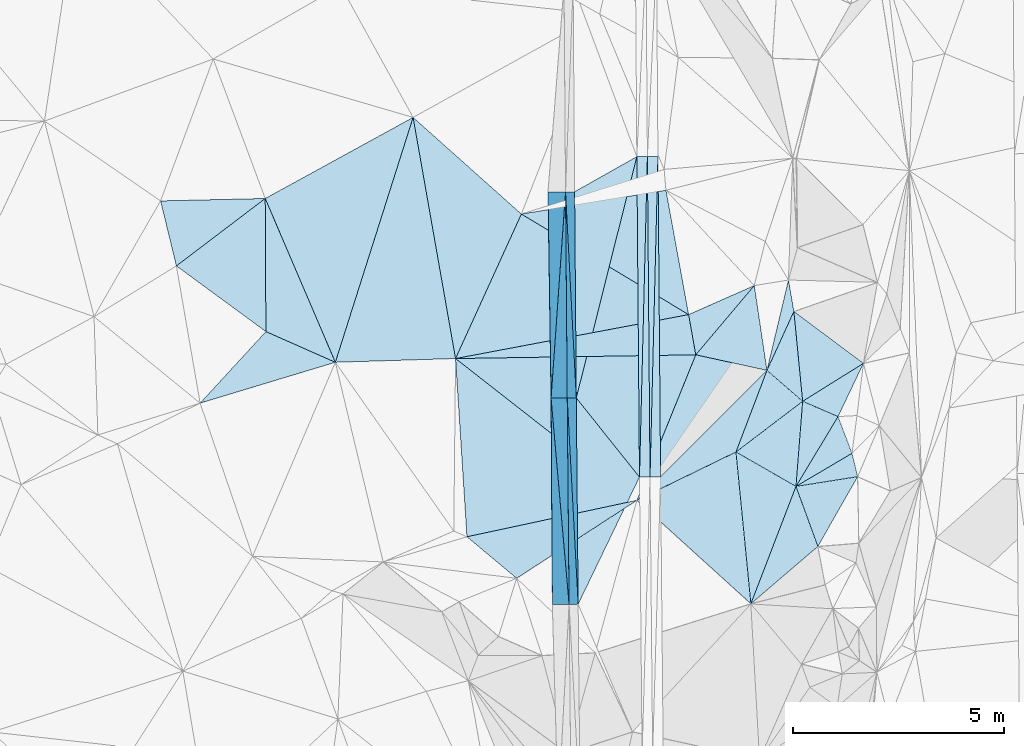
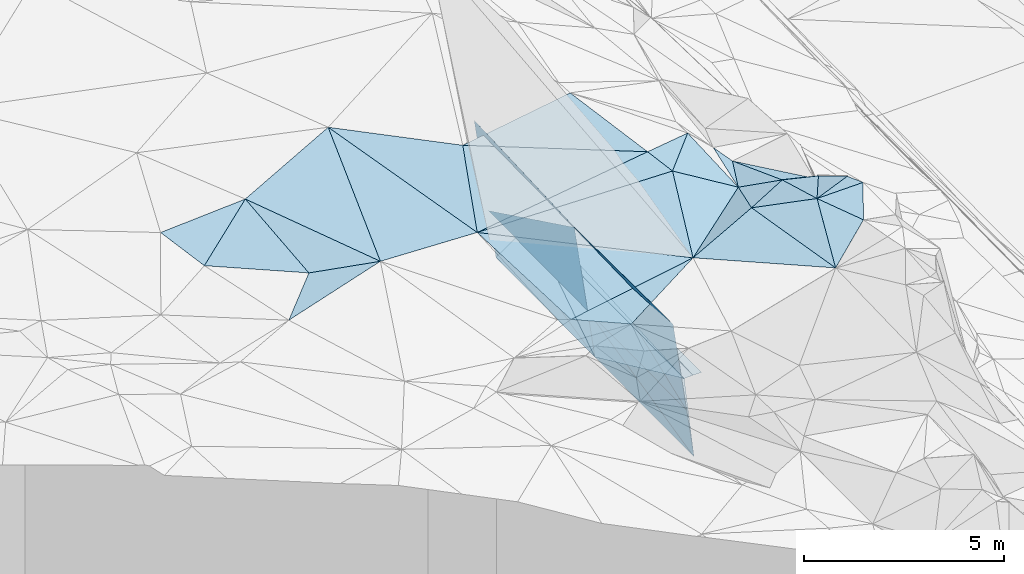
# One storey, part 19 of 275: 45 plates.
"""IFC2X3 building model written with IfcOpenShell, lengths in millimetres."""

from ifc_helpers import new_model, si_unit, frame, origin_with_axes, place, context, subcontext, project, spatial, polyline, outline, extrude, material, type_object, element, save


model = new_model("IFC2X3")

# Units and contexts
model_context = context("Model", 3, precision=1e-05, world=origin_with_axes())
body_context = subcontext(model_context, "Body", "Model", "MODEL_VIEW")
ifc_project = project(units=[si_unit("LENGTHUNIT", "METRE", prefix="MILLI"), si_unit("AREAUNIT", "SQUARE_METRE"), si_unit("VOLUMEUNIT", "CUBIC_METRE"), si_unit("MASSUNIT", "GRAM", prefix="KILO"), si_unit("TIMEUNIT", "SECOND"), si_unit("PLANEANGLEUNIT", "RADIAN"), si_unit("SOLIDANGLEUNIT", "STERADIAN"), si_unit("THERMODYNAMICTEMPERATUREUNIT", "DEGREE_CELSIUS"), si_unit("LUMINOUSINTENSITYUNIT", "LUMEN")], contexts=[model_context])

# Site, building, storey
site_placement = place(None, origin_with_axes())
site = spatial("IfcSite", under=ifc_project, at=site_placement, CompositionType="ELEMENT")
building_placement = place(site_placement, origin_with_axes())
building = spatial("IfcBuilding", under=site, at=building_placement, Name="Undefined", CompositionType="ELEMENT")
storey_placement = place(building_placement, origin_with_axes())
storey = spatial("IfcBuildingStorey", under=building, at=storey_placement, Name="Undefined", CompositionType="ELEMENT", Elevation=0.0)

# Plates
ifc_material = material()
plate_type_1 = type_object("IfcPlateType", PredefinedType="NOTDEFINED")
plate_1_placement = place(storey_placement, frame((-103921.728239516, 36919.7702889844, 41973.6237308018), z_axis=(0.0497692492091022, 0.0208905497116194, -0.998542240852088), x_axis=(0.998723320468431, 0.00761374111496485, 0.0499375620024224)))
element("IfcPlate", 1, at=plate_1_placement, inside=storey, type_object=plate_type_1, material=ifc_material, Name="00_PR", context=body_context, shape_type="SweptSolid", body=[
    extrude(outline(polyline([(0.0, 0.0), (250.312576293945, -3.78349795937538e-10), (-3.00748419761658, 7591.955078125), (0.0, 0.0)])), frame((-8.85201319254618e-08, 2.18876761149539e-07, -0.5000001331573), z_axis=(0.0, 0.0, 1.0), x_axis=(1.0, 0.0, 0.0)), (0.0, 0.0, 1.0), 1.0),
])
plate_2_placement = place(storey_placement, frame((-103671.735246054, 36921.6761023971, 41986.1237297089), z_axis=(0.049743498958775, 0.0208912133031926, -0.998543510077582), x_axis=(0.00825023810131896, -0.999755697538456, -0.020505579988562)))
element("IfcPlate", 2, at=plate_2_placement, inside=storey, type_object=plate_type_1, material=ifc_material, Name="00_PR", context=body_context, shape_type="SweptSolid", body=[
    extrude(outline(polyline([(0.0, 0.0), (7591.640625, 2.20461515709758e-08), (7592.0546875, 250.312301635742), (0.0, 0.0)])), frame((-8.85201319254618e-08, 2.18876761149539e-07, -0.5000001331573), z_axis=(0.0, 0.0, 1.0), x_axis=(1.0, 0.0, 0.0)), (0.0, 0.0, 1.0), 1.0),
])
plate_3_placement = place(storey_placement, frame((-103609.137362637, 29331.8896114708, 41830.4522061954), z_axis=(-0.0201732460180045, 0.0203365516157149, -0.999589648212444), x_axis=(0.0246672648762927, 0.999498886520807, 0.0198368819926245)))
element("IfcPlate", 3, at=plate_3_placement, inside=storey, type_object=plate_type_1, material=ifc_material, Name="00_PR", context=body_context, shape_type="SweptSolid", body=[
    extrude(outline(polyline([(0.0, 0.0), (7595.498046875, 6.41739461570978e-09), (8.28653717041016, 249.912078857422), (0.0, 0.0)])), frame((-8.85201319254618e-08, 2.18876761149539e-07, -0.5000001331573), z_axis=(0.0, 0.0, 1.0), x_axis=(1.0, 0.0, 0.0)), (0.0, 0.0, 1.0), 1.0),
])
plate_4_placement = place(storey_placement, frame((-103421.777179473, 36923.5816405609, 41981.1232056417), z_axis=(-0.0201473935407606, 0.0203359241728158, -0.999590182385537), x_axis=(-0.0246672648625445, -0.999498886521437, -0.0198368819780045)))
element("IfcPlate", 4, at=plate_4_placement, inside=storey, type_object=plate_type_1, material=ifc_material, Name="00_PR", context=body_context, shape_type="SweptSolid", body=[
    extrude(outline(polyline([(0.0, 0.0), (7595.498046875, 6.41739461570978e-09), (7.97231960296631, 249.923141479492), (0.0, 0.0)])), frame((-8.85201319254618e-08, 2.18876761149539e-07, -0.5000001331573), z_axis=(0.0, 0.0, 1.0), x_axis=(1.0, 0.0, 0.0)), (0.0, 0.0, 1.0), 1.0),
])
plate_type_2 = type_object("IfcPlateType", PredefinedType="NOTDEFINED")
plate_5_placement = place(storey_placement, frame((-101573.44969805, 29924.7296562743, 45869.5076663774), z_axis=(0.168990342988045, -0.0436568442276108, -0.98465036633765), x_axis=(0.85501951198308, -0.490462355806167, 0.168488313141538)))
element("IfcPlate", 5, at=plate_5_placement, inside=storey, type_object=plate_type_2, material=ifc_material, Name="00", context=body_context, shape_type="SweptSolid", body=[
    extrude(outline(polyline([(0.0, 0.0), (1661.83630371094, 1.65528035722673e-09), (2101.95190429688, 2944.82568359375), (0.0, 0.0)])), frame((-8.85201319254618e-08, 2.18876761149539e-07, -0.5000001331573), z_axis=(0.0, 0.0, 1.0), x_axis=(1.0, 0.0, 0.0)), (0.0, 0.0, 1.0), 1.0),
])
plate_type_3 = type_object("IfcPlateType", PredefinedType="NOTDEFINED")
plate_6_placement = place(storey_placement, frame((-103921.327531141, 28780.4761888303, 45858.565501627), z_axis=(0.220043812322641, -0.443233428239793, -0.868979199261593), x_axis=(0.696354859847022, 0.695205713028764, -0.178266445916226)))
element("IfcPlate", 6, at=plate_6_placement, inside=storey, type_object=plate_type_3, material=ifc_material, Name="00", context=body_context, shape_type="SweptSolid", body=[
    extrude(outline(polyline([(0.0, 0.0), (4425.958984375, -1.13213900476694e-08), (2428.36572265625, 961.597778320313), (0.0, 0.0)])), frame((-8.85201319254618e-08, 2.18876761149539e-07, -0.5000001331573), z_axis=(0.0, 0.0, 1.0), x_axis=(1.0, 0.0, 0.0)), (0.0, 0.0, 1.0), 1.0),
])
plate_type_4 = type_object("IfcPlateType", PredefinedType="NOTDEFINED")
plate_7_placement = place(storey_placement, frame((-100152.673837097, 29109.5207801058, 46149.5290304799), z_axis=(-0.0842694409372019, -0.325084643046942, -0.941922839822442), x_axis=(0.0738510628752179, 0.940647822764666, -0.331251707980947)))
element("IfcPlate", 7, at=plate_7_placement, inside=storey, type_object=plate_type_4, material=ifc_material, Name="00", context=body_context, shape_type="SweptSolid", body=[
    extrude(outline(polyline([(0.0, 0.0), (2143.38525390625, -2.4156179279089e-09), (1848.10461425781, 865.22216796875), (0.0, 0.0)])), frame((-8.85201319254618e-08, 2.18876761149539e-07, -0.5000001331573), z_axis=(0.0, 0.0, 1.0), x_axis=(1.0, 0.0, 0.0)), (0.0, 0.0, 1.0), 1.0),
])
plate_type_5 = type_object("IfcPlateType", PredefinedType="NOTDEFINED")
plate_8_placement = place(storey_placement, frame((-99633.5834360624, 27688.1634661407, 46179.5033105003), z_axis=(-0.0996928858655477, -0.0573702320658693, -0.993362967389316), x_axis=(-0.342954816288866, 0.939142775312888, -0.0198202311256917)))
element("IfcPlate", 8, at=plate_8_placement, inside=storey, type_object=plate_type_5, material=ifc_material, Name="00", context=body_context, shape_type="SweptSolid", body=[
    extrude(outline(polyline([(0.0, 0.0), (1513.60498046875, -5.1368260756135e-09), (1232.15771484375, 1461.39916992188), (0.0, 0.0)])), frame((-8.85201319254618e-08, 2.18876761149539e-07, -0.5000001331573), z_axis=(0.0, 0.0, 1.0), x_axis=(1.0, 0.0, 0.0)), (0.0, 0.0, 1.0), 1.0),
])
plate_type_6 = type_object("IfcPlateType", PredefinedType="NOTDEFINED")
plate_9_placement = place(storey_placement, frame((-105610.177863287, 36086.7989861103, 43457.3042912), z_axis=(-0.989935969348998, -0.00518439938245923, -0.141420997705799), x_axis=(-0.0618485549238657, -0.882987096912593, 0.465304784995492)))
element("IfcPlate", 9, at=plate_9_placement, inside=storey, type_object=plate_type_6, material=ifc_material, Name="00_PR", context=body_context, shape_type="SweptSolid", body=[
    extrude(outline(polyline([(0.0, 0.0), (5536.08544921875, -9.53150447458029e-09), (1381.64526367188, 2592.31591796875), (0.0, 0.0)])), frame((-8.85201319254618e-08, 2.18876761149539e-07, -0.5000001331573), z_axis=(0.0, 0.0, 1.0), x_axis=(1.0, 0.0, 0.0)), (0.0, 0.0, 1.0), 1.0),
])
plate_type_7 = type_object("IfcPlateType", PredefinedType="NOTDEFINED")
plate_10_placement = place(storey_placement, frame((-105356.019838784, 31203.6185060569, 41857.2232917788), z_axis=(-0.989935969348998, -0.00518439938245923, -0.141420997705799), x_axis=(-0.141416001052953, -0.00121137698710813, 0.98994951750682)))
element("IfcPlate", 10, at=plate_10_placement, inside=storey, type_object=plate_type_7, material=ifc_material, Name="00_PR", context=body_context, shape_type="SweptSolid", body=[
    extrude(outline(polyline([(0.0, 0.0), (1515.22875976563, -2.92493496090174e-09), (1614.02600097656, 4885.205078125), (0.0, 0.0)])), frame((-8.85201319254618e-08, 2.18876761149539e-07, -0.5000001331573), z_axis=(0.0, 0.0, 1.0), x_axis=(1.0, 0.0, 0.0)), (0.0, 0.0, 1.0), 1.0),
])
plate_11_placement = place(storey_placement, frame((-105312.183401715, 26318.8094043872, 41756.6242917704), z_axis=(-0.989931508689783, -0.00597113694313821, -0.14142119228311), x_axis=(-0.141415544963165, -0.00132663298385936, 0.989949434914581)))
element("IfcPlate", 11, at=plate_11_placement, inside=storey, type_object=plate_type_7, material=ifc_material, Name="00_PR", context=body_context, shape_type="SweptSolid", body=[
    extrude(outline(polyline([(0.0, 0.0), (1515.22888183594, -4.05998434871435e-09), (1614.53552246094, 4885.20654296875), (0.0, 0.0)])), frame((-8.85201319254618e-08, 2.18876761149539e-07, -0.5000001331573), z_axis=(0.0, 0.0, 1.0), x_axis=(1.0, 0.0, 0.0)), (0.0, 0.0, 1.0), 1.0),
])
plate_12_placement = place(storey_placement, frame((-105610.177863287, 36086.7989861103, 43457.3042912), z_axis=(-0.989935969348998, -0.00518439938245923, -0.141420997705799), x_axis=(0.141417375993781, 0.001097257012351, -0.989949454161212)))
element("IfcPlate", 12, at=plate_12_placement, inside=storey, type_object=plate_type_7, material=ifc_material, Name="00_PR", context=body_context, shape_type="SweptSolid", body=[
    extrude(outline(polyline([(0.0, 0.0), (1515.22888183594, -4.05998434871435e-09), (1614.58361816406, 4885.0205078125), (0.0, 0.0)])), frame((-8.85201319254618e-08, 2.18876761149539e-07, -0.5000001331573), z_axis=(0.0, 0.0, 1.0), x_axis=(1.0, 0.0, 0.0)), (0.0, 0.0, 1.0), 1.0),
])
plate_13_placement = place(storey_placement, frame((-105570.297434262, 31201.7825974093, 43357.2232907321), z_axis=(-0.989931508689783, -0.00597113694313821, -0.14142119228311), x_axis=(0.141416446037978, 0.00121186498716629, -0.989949453342564)))
element("IfcPlate", 13, at=plate_13_placement, inside=storey, type_object=plate_type_7, material=ifc_material, Name="00_PR", context=body_context, shape_type="SweptSolid", body=[
    extrude(outline(polyline([(0.0, 0.0), (1515.22875976563, -2.92493496090174e-09), (1615.09851074219, 4885.0205078125), (0.0, 0.0)])), frame((-8.85201319254618e-08, 2.18876761149539e-07, -0.5000001331573), z_axis=(0.0, 0.0, 1.0), x_axis=(1.0, 0.0, 0.0)), (0.0, 0.0, 1.0), 1.0),
])
plate_type_8 = type_object("IfcPlateType", PredefinedType="NOTDEFINED")
plate_14_placement = place(storey_placement, frame((-105952.576747577, 31198.507059435, 46033.2712917029), z_axis=(-0.989935969348998, -0.00518439938245923, -0.141420997705799), x_axis=(0.0618485549161075, 0.882987096917391, -0.465304784987417)))
element("IfcPlate", 14, at=plate_14_placement, inside=storey, type_object=plate_type_8, material=ifc_material, Name="00_PR", context=body_context, shape_type="SweptSolid", body=[
    extrude(outline(polyline([(0.0, 0.0), (5536.08544921875, -9.53150447458029e-09), (1271.71398925781, 2385.39819335938), (0.0, 0.0)])), frame((-8.85201319254618e-08, 2.18876761149539e-07, -0.5000001331573), z_axis=(0.0, 0.0, 1.0), x_axis=(1.0, 0.0, 0.0)), (0.0, 0.0, 1.0), 1.0),
])
plate_type_9 = type_object("IfcPlateType", PredefinedType="NOTDEFINED")
plate_15_placement = place(storey_placement, frame((-105952.576744661, 31198.5066657955, 46033.2712916076), z_axis=(-0.989931508689783, -0.00597113694313821, -0.14142119228311), x_axis=(0.141416446037978, 0.00121186498716629, -0.989949453342564)))
element("IfcPlate", 15, at=plate_15_placement, inside=storey, type_object=plate_type_9, material=ifc_material, Name="00_PR", context=body_context, shape_type="SweptSolid", body=[
    extrude(outline(polyline([(0.0, 0.0), (2703.216796875, 5.84986992180347e-09), (2803.083984375, 4885.19482421875), (0.0, 0.0)])), frame((-8.85201319254618e-08, 2.18876761149539e-07, -0.5000001331573), z_axis=(0.0, 0.0, 1.0), x_axis=(1.0, 0.0, 0.0)), (0.0, 0.0, 1.0), 1.0),
])
plate_type_10 = type_object("IfcPlateType", PredefinedType="NOTDEFINED")
plate_16_placement = place(storey_placement, frame((-105526.460324405, 26316.7992505313, 43256.6242918833), z_axis=(-0.989931592785669, -0.00597148737116309, -0.141420588824276), x_axis=(-0.141415146919872, -0.00132605298786236, 0.989949492552577)))
element("IfcPlate", 16, at=plate_16_placement, inside=storey, type_object=plate_type_10, material=ifc_material, Name="00_PR", context=body_context, shape_type="SweptSolid", body=[
    extrude(outline(polyline([(0.0, 0.0), (2803.37744140625, 4.34010871686041e-09), (2802.52612304688, 4885.51513671875), (0.0, 0.0)])), frame((-8.85201319254618e-08, 2.18876761149539e-07, -0.5000001331573), z_axis=(0.0, 0.0, 1.0), x_axis=(1.0, 0.0, 0.0)), (0.0, 0.0, 1.0), 1.0),
])
plate_type_11 = type_object("IfcPlateType", PredefinedType="NOTDEFINED")
plate_17_placement = place(storey_placement, frame((-105311.688522179, 26318.8226818034, 41756.1951075937), z_axis=(-0.000168348709010143, 0.0205883792620506, -0.999788022681845), x_axis=(-0.00897176910040704, 0.999747767152547, 0.0205890609962038)))
element("IfcPlate", 17, at=plate_17_placement, inside=storey, type_object=plate_type_11, material=ifc_material, Name="00_PR", context=body_context, shape_type="SweptSolid", body=[
    extrude(outline(polyline([(0.0, 0.0), (4886.041015625, -6.67932908982039e-09), (2998.32641601563, 1479.53051757813), (0.0, 0.0)])), frame((-8.85201319254618e-08, 2.18876761149539e-07, -0.5000001331573), z_axis=(0.0, 0.0, 1.0), x_axis=(1.0, 0.0, 0.0)), (0.0, 0.0, 1.0), 1.0),
])
plate_type_12 = type_object("IfcPlateType", PredefinedType="NOTDEFINED")
plate_18_placement = place(storey_placement, frame((-105355.524967163, 31203.6313372193, 41856.7941065593), z_axis=(-0.000191554318653661, 0.0204822067447616, -0.999790199248726), x_axis=(-0.00816170409994989, 0.999756885293786, 0.0204830879960041)))
element("IfcPlate", 18, at=plate_18_placement, inside=storey, type_object=plate_type_12, material=ifc_material, Name="00_PR", context=body_context, shape_type="SweptSolid", body=[
    extrude(outline(polyline([(0.0, 0.0), (4886.03076171875, -6.50470610707998e-09), (5705.43994140625, 1480.38720703125), (0.0, 0.0)])), frame((-8.85201319254618e-08, 2.18876761149539e-07, -0.5000001331573), z_axis=(0.0, 0.0, 1.0), x_axis=(1.0, 0.0, 0.0)), (0.0, 0.0, 1.0), 1.0),
])
plate_type_13 = type_object("IfcPlateType", PredefinedType="NOTDEFINED")
plate_19_placement = place(storey_placement, frame((-105355.525010535, 31203.6313468472, 41856.7941064958), z_axis=(-0.000275117949097491, 0.0205031572270465, -0.999789750324456), x_axis=(0.24324429095761, 0.969762530248869, 0.0198204400012125)))
element("IfcPlate", 19, at=plate_19_placement, inside=storey, type_object=plate_type_13, material=ifc_material, Name="00_PR", context=body_context, shape_type="SweptSolid", body=[
    extrude(outline(polyline([(0.0, 0.0), (5894.36962890625, 1.51339918375015e-08), (-1454.07580566406, 1907.39123535156), (0.0, 0.0)])), frame((-8.85201319254618e-08, 2.18876761149539e-07, -0.5000001331573), z_axis=(0.0, 0.0, 1.0), x_axis=(1.0, 0.0, 0.0)), (0.0, 0.0, 1.0), 1.0),
])
plate_20_placement = place(storey_placement, frame((-99994.3426616482, 31125.6879965323, 45439.5283297592), z_axis=(-0.00446505824452296, -0.331843531683021, -0.943323875312723), x_axis=(-0.0738510628753128, -0.940647822765727, 0.331251707977911)))
element("IfcPlate", 20, at=plate_20_placement, inside=storey, type_object=plate_type_13, material=ifc_material, Name="00", context=body_context, shape_type="SweptSolid", body=[
    extrude(outline(polyline([(0.0, 0.0), (2143.38525390625, -2.4156179279089e-09), (1388.87780761719, 1480.68176269531), (0.0, 0.0)])), frame((-8.85201319254618e-08, 2.18876761149539e-07, -0.5000001331573), z_axis=(0.0, 0.0, 1.0), x_axis=(1.0, 0.0, 0.0)), (0.0, 0.0, 1.0), 1.0),
])
plate_type_14 = type_object("IfcPlateType", PredefinedType="NOTDEFINED")
plate_21_placement = place(storey_placement, frame((-101573.50684697, 29924.5517261748, 45869.5424452308), z_axis=(0.0546933566105173, -0.399517333410453, -0.915092638505674), x_axis=(0.331140138053792, 0.871856583417148, -0.36084942416733)))
element("IfcPlate", 21, at=plate_21_placement, inside=storey, type_object=plate_type_14, material=ifc_material, Name="00", context=body_context, shape_type="SweptSolid", body=[
    extrude(outline(polyline([(0.0, 0.0), (2216.9912109375, 9.02218744158745e-10), (1725.28881835938, 1069.943359375), (0.0, 0.0)])), frame((-8.85201319254618e-08, 2.18876761149539e-07, -0.5000001331573), z_axis=(0.0, 0.0, 1.0), x_axis=(1.0, 0.0, 0.0)), (0.0, 0.0, 1.0), 1.0),
])
plate_type_15 = type_object("IfcPlateType", PredefinedType="NOTDEFINED")
plate_22_placement = place(storey_placement, frame((-98826.1026830501, 29892.8605451238, 45889.511125102), z_axis=(-0.0761767903599321, -0.195534351400637, -0.977733815530992), x_axis=(0.233684383182157, -0.956773531153767, 0.173135840138104)))
element("IfcPlate", 22, at=plate_22_placement, inside=storey, type_object=plate_type_15, material=ifc_material, Name="00", context=body_context, shape_type="SweptSolid", body=[
    extrude(outline(polyline([(0.0, 0.0), (577.581176757813, 8.00355337560177e-10), (484.43408203125, 1485.33618164063), (0.0, 0.0)])), frame((-8.85201319254618e-08, 2.18876761149539e-07, -0.5000001331573), z_axis=(0.0, 0.0, 1.0), x_axis=(1.0, 0.0, 0.0)), (0.0, 0.0, 1.0), 1.0),
])
plate_type_16 = type_object("IfcPlateType", PredefinedType="NOTDEFINED")
plate_23_placement = place(storey_placement, frame((-107945.741226028, 27916.695117174, 45909.5005678113), z_axis=(-0.00226451258230873, -0.0484120677944411, -0.998824881385436), x_axis=(0.977646261446697, 0.209891120456611, -0.0123897147975776)))
element("IfcPlate", 23, at=plate_23_placement, inside=storey, type_object=plate_type_16, material=ifc_material, Name="00", context=body_context, shape_type="SweptSolid", body=[
    extrude(outline(polyline([(0.0, 0.0), (4116.3173828125, -1.81753421202302e-08), (942.813537597656, 1209.72583007813), (0.0, 0.0)])), frame((-8.85201319254618e-08, 2.18876761149539e-07, -0.5000001331573), z_axis=(0.0, 0.0, 1.0), x_axis=(1.0, 0.0, 0.0)), (0.0, 0.0, 1.0), 1.0),
])
plate_type_17 = type_object("IfcPlateType", PredefinedType="NOTDEFINED")
plate_24_placement = place(storey_placement, frame((-100839.553875385, 31857.6284578446, 45069.524928277), z_axis=(-0.308910515147963, -0.042807738563746, -0.950127249977643), x_axis=(0.229949200931108, 0.96598763234246, -0.1182846530728)))
element("IfcPlate", 24, at=plate_24_placement, inside=storey, type_object=plate_type_17, material=ifc_material, Name="00", context=body_context, shape_type="SweptSolid", body=[
    extrude(outline(polyline([(0.0, 0.0), (2214.99560546875, 4.55474946647882e-09), (1526.71447753906, 309.859527587891), (0.0, 0.0)])), frame((-8.85201319254618e-08, 2.18876761149539e-07, -0.5000001331573), z_axis=(0.0, 0.0, 1.0), x_axis=(1.0, 0.0, 0.0)), (0.0, 0.0, 1.0), 1.0),
])
plate_type_18 = type_object("IfcPlateType", PredefinedType="NOTDEFINED")
plate_25_placement = place(storey_placement, frame((-102525.600362105, 32226.3968501853, 45929.5165440463), z_axis=(-0.253930474291713, 0.0258032767464417, -0.966878226632047), x_axis=(-0.174926036604537, 0.981934757436146, 0.0721457819740322)))
element("IfcPlate", 25, at=plate_25_placement, inside=storey, type_object=plate_type_18, material=ifc_material, Name="00", context=body_context, shape_type="SweptSolid", body=[
    extrude(outline(polyline([(0.0, 0.0), (970.257690429688, 1.33877620100975e-09), (1345.10656738281, 1703.40490722656), (0.0, 0.0)])), frame((-8.85201319254618e-08, 2.18876761149539e-07, -0.5000001331573), z_axis=(0.0, 0.0, 1.0), x_axis=(1.0, 0.0, 0.0)), (0.0, 0.0, 1.0), 1.0),
])
plate_type_19 = type_object("IfcPlateType", PredefinedType="NOTDEFINED")
plate_26_placement = place(storey_placement, frame((-100202.576781446, 33253.2670548351, 44799.5694963486), z_axis=(-0.411294638274613, -0.299214175688879, -0.860992216918005), x_axis=(0.789584541832046, -0.588888063660195, -0.172531445766923)))
element("IfcPlate", 26, at=plate_26_placement, inside=storey, type_object=plate_type_19, material=ifc_material, Name="00", context=body_context, shape_type="SweptSolid", body=[
    extrude(outline(polyline([(0.0, 0.0), (2086.576171875, -6.19911588728428e-09), (1306.73400878906, 1808.82458496094), (0.0, 0.0)])), frame((-8.85201319254618e-08, 2.18876761149539e-07, -0.5000001331573), z_axis=(0.0, 0.0, 1.0), x_axis=(1.0, 0.0, 0.0)), (0.0, 0.0, 1.0), 1.0),
])
plate_type_20 = type_object("IfcPlateType", PredefinedType="NOTDEFINED")
plate_27_placement = place(storey_placement, frame((-99156.4730368533, 30763.4753863264, 45489.6011717497), z_axis=(-0.198505195880907, -0.569528801965936, -0.797641918995942), x_axis=(-0.916590919242883, 0.396068100926578, -0.0546913721705874)))
element("IfcPlate", 27, at=plate_27_placement, inside=storey, type_object=plate_type_20, material=ifc_material, Name="00", context=body_context, shape_type="SweptSolid", body=[
    extrude(outline(polyline([(0.0, 0.0), (914.221008300781, -5.39148459210992e-09), (5.46913719177246, 1747.61840820313), (0.0, 0.0)])), frame((-8.85201319254618e-08, 2.18876761149539e-07, -0.5000001331573), z_axis=(0.0, 0.0, 1.0), x_axis=(1.0, 0.0, 0.0)), (0.0, 0.0, 1.0), 1.0),
])
plate_type_21 = type_object("IfcPlateType", PredefinedType="NOTDEFINED")
plate_28_placement = place(storey_placement, frame((-99994.2487680686, 31125.7205683498, 45439.5269002303), z_axis=(0.183322169816047, -0.266700049025362, -0.946183949295171), x_axis=(-0.717660855861682, 0.621472949689248, -0.314220096060745)))
element("IfcPlate", 28, at=plate_28_placement, inside=storey, type_object=plate_type_21, material=ifc_material, Name="00", context=body_context, shape_type="SweptSolid", body=[
    extrude(outline(polyline([(0.0, 0.0), (1177.5185546875, 1.70257408171892e-09), (1672.61901855469, 1477.0732421875), (0.0, 0.0)])), frame((-8.85201319254618e-08, 2.18876761149539e-07, -0.5000001331573), z_axis=(0.0, 0.0, 1.0), x_axis=(1.0, 0.0, 0.0)), (0.0, 0.0, 1.0), 1.0),
])
plate_type_22 = type_object("IfcPlateType", PredefinedType="NOTDEFINED")
plate_29_placement = place(storey_placement, frame((-100152.60325942, 29109.683173678, 46149.5008015184), z_axis=(0.056886697419023, -0.000296618700455997, -0.998380596603371), x_axis=(0.342954816289884, -0.939142775312598, 0.0198202311218358)))
element("IfcPlate", 29, at=plate_29_placement, inside=storey, type_object=plate_type_22, material=ifc_material, Name="00", context=body_context, shape_type="SweptSolid", body=[
    extrude(outline(polyline([(0.0, 0.0), (1513.60498046875, -5.1368260756135e-09), (2242.52709960938, 1958.76818847656), (0.0, 0.0)])), frame((-8.85201319254618e-08, 2.18876761149539e-07, -0.5000001331573), z_axis=(0.0, 0.0, 1.0), x_axis=(1.0, 0.0, 0.0)), (0.0, 0.0, 1.0), 1.0),
])
plate_type_23 = type_object("IfcPlateType", PredefinedType="NOTDEFINED")
plate_30_placement = place(storey_placement, frame((-101220.12532183, 26330.7117412105, 46089.5010997697), z_axis=(0.0328611234094255, -0.0578461602426955, -0.99778453000307), x_axis=(-0.739245025330031, 0.670462905077913, -0.0632161802016514)))
element("IfcPlate", 30, at=plate_30_placement, inside=storey, type_object=plate_type_23, material=ifc_material, Name="00", context=body_context, shape_type="SweptSolid", body=[
    extrude(outline(polyline([(0.0, 0.0), (3654.12768554688, -9.42236511036754e-09), (2684.80200195313, 2425.29125976563), (0.0, 0.0)])), frame((-8.85201319254618e-08, 2.18876761149539e-07, -0.5000001331573), z_axis=(0.0, 0.0, 1.0), x_axis=(1.0, 0.0, 0.0)), (0.0, 0.0, 1.0), 1.0),
])
plate_type_24 = type_object("IfcPlateType", PredefinedType="NOTDEFINED")
plate_31_placement = place(storey_placement, frame((-112723.432030578, 35929.1285674692, 46399.5043328628), z_axis=(0.0716689360214232, 0.110417403113903, -0.991297917227278), x_axis=(0.00509062969223, -0.993881184755208, -0.11033710200527)))
element("IfcPlate", 31, at=plate_31_placement, inside=storey, type_object=plate_type_24, material=ifc_material, Name="00", context=body_context, shape_type="SweptSolid", body=[
    extrude(outline(polyline([(0.0, 0.0), (3172.09716796875, 2.88127921521664e-09), (1613.00231933594, 2117.57495117188), (0.0, 0.0)])), frame((-8.85201319254618e-08, 2.18876761149539e-07, -0.5000001331573), z_axis=(0.0, 0.0, 1.0), x_axis=(1.0, 0.0, 0.0)), (0.0, 0.0, 1.0), 1.0),
])
plate_type_25 = type_object("IfcPlateType", PredefinedType="NOTDEFINED")
plate_32_placement = place(storey_placement, frame((-99156.345756694, 30763.5606409484, 45489.5423826535), z_axis=(0.0562502222602138, -0.399057107547727, -0.915199069826515), x_axis=(0.32587487024772, -0.859111547397936, 0.394630102841327)))
element("IfcPlate", 32, at=plate_32_placement, inside=storey, type_object=plate_type_25, material=ifc_material, Name="00", context=body_context, shape_type="SweptSolid", body=[
    extrude(outline(polyline([(0.0, 0.0), (1013.607421875, -1.45519152283669e-10), (1356.8369140625, 1524.16979980469), (0.0, 0.0)])), frame((-8.85201319254618e-08, 2.18876761149539e-07, -0.5000001331573), z_axis=(0.0, 0.0, 1.0), x_axis=(1.0, 0.0, 0.0)), (0.0, 0.0, 1.0), 1.0),
])
plate_type_26 = type_object("IfcPlateType", PredefinedType="NOTDEFINED")
plate_33_placement = place(storey_placement, frame((-111062.778649326, 32049.2686948811, 46269.5111293957), z_axis=(0.179202835506814, 0.109459037560141, -0.977703975057239), x_axis=(-0.907802806268224, 0.401427780387612, -0.121448763125082)))
element("IfcPlate", 33, at=plate_33_placement, inside=storey, type_object=plate_type_26, material=ifc_material, Name="00", context=body_context, shape_type="SweptSolid", body=[
    extrude(outline(polyline([(0.0, 0.0), (1811.46350097656, 4.09636413678527e-09), (3049.19189453125, 2920.65551757813), (0.0, 0.0)])), frame((-8.85201319254618e-08, 2.18876761149539e-07, -0.5000001331573), z_axis=(0.0, 0.0, 1.0), x_axis=(1.0, 0.0, 0.0)), (0.0, 0.0, 1.0), 1.0),
])
plate_type_27 = type_object("IfcPlateType", PredefinedType="NOTDEFINED")
plate_34_placement = place(storey_placement, frame((-111062.898755051, 32049.2176316252, 46269.5009269491), z_axis=(-0.0610102581763005, 0.00733034688543529, -0.998110221574652), x_axis=(-0.393292855427785, 0.918897585270988, 0.0307889209392996)))
element("IfcPlate", 34, at=plate_34_placement, inside=storey, type_object=plate_type_27, material=ifc_material, Name="00", context=body_context, shape_type="SweptSolid", body=[
    extrude(outline(polyline([(0.0, 0.0), (4222.2978515625, 1.07538653537631e-08), (4603.0859375, 3981.33154296875), (0.0, 0.0)])), frame((-8.85201319254618e-08, 2.18876761149539e-07, -0.5000001331573), z_axis=(0.0, 0.0, 1.0), x_axis=(1.0, 0.0, 0.0)), (0.0, 0.0, 1.0), 1.0),
])
plate_type_28 = type_object("IfcPlateType", PredefinedType="NOTDEFINED")
plate_35_placement = place(storey_placement, frame((-101140.572615148, 33866.5865178447, 45609.554059598), z_axis=(-0.416100101136491, 0.177398026548873, -0.891846761507137), x_axis=(0.143192551742919, -0.95576563423365, -0.25692011510059)))
element("IfcPlate", 35, at=plate_35_placement, inside=storey, type_object=plate_type_28, material=ifc_material, Name="00", context=body_context, shape_type="SweptSolid", body=[
    extrude(outline(polyline([(0.0, 0.0), (2101.82055664063, 3.56521923094988e-09), (1287.01281738281, 1747.71228027344), (0.0, 0.0)])), frame((-8.85201319254618e-08, 2.18876761149539e-07, -0.5000001331573), z_axis=(0.0, 0.0, 1.0), x_axis=(1.0, 0.0, 0.0)), (0.0, 0.0, 1.0), 1.0),
])
plate_type_29 = type_object("IfcPlateType", PredefinedType="NOTDEFINED")
plate_36_placement = place(storey_placement, frame((-102695.193655362, 33179.1481467782, 45999.5011805394), z_axis=(0.00615621473133686, 0.068881032541319, -0.997605886297902), x_axis=(-0.856632317693024, 0.515038330624429, 0.0302752418896893)))
element("IfcPlate", 36, at=plate_36_placement, inside=storey, type_object=plate_type_29, material=ifc_material, Name="00", context=body_context, shape_type="SweptSolid", body=[
    extrude(outline(polyline([(0.0, 0.0), (4624.240234375, -2.77868821285665e-08), (1982.1201171875, 2251.51049804688), (0.0, 0.0)])), frame((-8.85201319254618e-08, 2.18876761149539e-07, -0.5000001331573), z_axis=(0.0, 0.0, 1.0), x_axis=(1.0, 0.0, 0.0)), (0.0, 0.0, 1.0), 1.0),
])
plate_type_30 = type_object("IfcPlateType", PredefinedType="NOTDEFINED")
plate_37_placement = place(storey_placement, frame((-112707.284831517, 32776.315623147, 46049.5061649162), z_axis=(0.0701209465194341, -0.140226597626921, -0.987633309572534), x_axis=(0.907802806267498, -0.401427780390231, 0.121448763121851)))
element("IfcPlate", 37, at=plate_37_placement, inside=storey, type_object=plate_type_30, material=ifc_material, Name="00", context=body_context, shape_type="SweptSolid", body=[
    extrude(outline(polyline([(0.0, 0.0), (1811.46350097656, 4.09636413678527e-09), (-718.148620605469, 2190.81323242188), (0.0, 0.0)])), frame((-8.85201319254618e-08, 2.18876761149539e-07, -0.5000001331573), z_axis=(0.0, 0.0, 1.0), x_axis=(1.0, 0.0, 0.0)), (0.0, 0.0, 1.0), 1.0),
])
plate_type_31 = type_object("IfcPlateType", PredefinedType="NOTDEFINED")
plate_38_placement = place(storey_placement, frame((-109220.812805101, 37849.3352479358, 46199.5000670548), z_axis=(-0.00921825360289613, 0.0158839120717178, -0.999831348347215), x_axis=(0.745973541216811, -0.66574681927409, -0.0174541808998192)))
element("IfcPlate", 38, at=plate_38_placement, inside=storey, type_object=plate_type_31, material=ifc_material, Name="00", context=body_context, shape_type="SweptSolid", body=[
    extrude(outline(polyline([(0.0, 0.0), (3437.57177734375, -1.9237631931901e-08), (4553.82470703125, 3591.89086914063), (0.0, 0.0)])), frame((-8.85201319254618e-08, 2.18876761149539e-07, -0.5000001331573), z_axis=(0.0, 0.0, 1.0), x_axis=(1.0, 0.0, 0.0)), (0.0, 0.0, 1.0), 1.0),
])
plate_type_32 = type_object("IfcPlateType", PredefinedType="NOTDEFINED")
plate_39_placement = place(storey_placement, frame((-108215.687607253, 32138.0548744521, 46099.5008898602), z_axis=(-0.059816062029005, 0.00695017731020874, -0.998185220166427), x_axis=(-0.997738429859385, -0.0311310036715616, 0.0595725288377987)))
element("IfcPlate", 39, at=plate_39_placement, inside=storey, type_object=plate_type_32, material=ifc_material, Name="00", context=body_context, shape_type="SweptSolid", body=[
    extrude(outline(polyline([(0.0, 0.0), (2853.66430664063, -6.60656951367855e-09), (831.036804199219, 5740.06787109375), (0.0, 0.0)])), frame((-8.85201319254618e-08, 2.18876761149539e-07, -0.5000001331573), z_axis=(0.0, 0.0, 1.0), x_axis=(1.0, 0.0, 0.0)), (0.0, 0.0, 1.0), 1.0),
])
plate_type_33 = type_object("IfcPlateType", PredefinedType="NOTDEFINED")
plate_40_placement = place(storey_placement, frame((-102695.207842591, 33179.1246070467, 45999.5002259065), z_axis=(-0.0222170700711187, 0.021801699706486, -0.999515426437913), x_axis=(-0.982523320600026, -0.18528669961352, 0.0177978488427104)))
element("IfcPlate", 40, at=plate_40_placement, inside=storey, type_object=plate_type_33, material=ifc_material, Name="00", context=body_context, shape_type="SweptSolid", body=[
    extrude(outline(polyline([(0.0, 0.0), (5618.65625, 2.21552909351885e-08), (3453.24560546875, 3075.49926757813), (0.0, 0.0)])), frame((-8.85201319254618e-08, 2.18876761149539e-07, -0.5000001331573), z_axis=(0.0, 0.0, 1.0), x_axis=(1.0, 0.0, 0.0)), (0.0, 0.0, 1.0), 1.0),
])
plate_type_34 = type_object("IfcPlateType", PredefinedType="NOTDEFINED")
plate_41_placement = place(storey_placement, frame((-102525.488823158, 32226.4178363375, 45929.5013716391), z_axis=(-0.0308451713790502, 0.0677742222983531, -0.997223761346695), x_axis=(-0.999433701253797, -0.0155148796786907, 0.0298590908550805)))
element("IfcPlate", 41, at=plate_41_placement, inside=storey, type_object=plate_type_34, material=ifc_material, Name="00", context=body_context, shape_type="SweptSolid", body=[
    extrude(outline(polyline([(0.0, 0.0), (5693.40869140625, -5.34782884642482e-09), (156.93586730957, 957.481689453125), (0.0, 0.0)])), frame((-8.85201319254618e-08, 2.18876761149539e-07, -0.5000001331573), z_axis=(0.0, 0.0, 1.0), x_axis=(1.0, 0.0, 0.0)), (0.0, 0.0, 1.0), 1.0),
])
plate_type_35 = type_object("IfcPlateType", PredefinedType="NOTDEFINED")
plate_42_placement = place(storey_placement, frame((-102525.6803259, 32226.4769626388, 45929.554415748), z_axis=(-0.413850098642002, 0.186026967174474, -0.891135266577343), x_axis=(0.874375475385605, -0.191220577442938, -0.445984549963996)))
element("IfcPlate", 42, at=plate_42_placement, inside=storey, type_object=plate_type_35, material=ifc_material, Name="00", context=body_context, shape_type="SweptSolid", body=[
    extrude(outline(polyline([(0.0, 0.0), (1928.31787109375, -1.3349563232623e-08), (-530.0458984375, 3680.42944335938), (0.0, 0.0)])), frame((-8.85201319254618e-08, 2.18876761149539e-07, -0.5000001331573), z_axis=(0.0, 0.0, 1.0), x_axis=(1.0, 0.0, 0.0)), (0.0, 0.0, 1.0), 1.0),
])
plate_type_36 = type_object("IfcPlateType", PredefinedType="NOTDEFINED")
plate_43_placement = place(storey_placement, frame((-103921.452807737, 28780.7142668126, 45858.5004838417), z_axis=(-0.0303565449615702, 0.0328832958525366, -0.998998082596694), x_axis=(-0.787033470322333, 0.61532701937742, 0.0441698518956635)))
element("IfcPlate", 43, at=plate_43_placement, inside=storey, type_object=plate_type_36, material=ifc_material, Name="00", context=body_context, shape_type="SweptSolid", body=[
    extrude(outline(polyline([(0.0, 0.0), (5456.21044921875, 1.16051523946226e-08), (1024.68920898438, 3574.42602539063), (0.0, 0.0)])), frame((-8.85201319254618e-08, 2.18876761149539e-07, -0.5000001331573), z_axis=(0.0, 0.0, 1.0), x_axis=(1.0, 0.0, 0.0)), (0.0, 0.0, 1.0), 1.0),
])
plate_type_37 = type_object("IfcPlateType", PredefinedType="NOTDEFINED")
plate_44_placement = place(storey_placement, frame((-114827.336429016, 34332.0727497008, 46069.5058096798), z_axis=(0.0444979858815899, 0.145600108967971, -0.988342317985523), x_axis=(-0.234357335600837, 0.963236104555231, 0.131350089955587)))
element("IfcPlate", 44, at=plate_44_placement, inside=storey, type_object=plate_type_37, material=ifc_material, Name="00", context=body_context, shape_type="SweptSolid", body=[
    extrude(outline(polyline([(0.0, 0.0), (1598.78076171875, 2.09547579288483e-09), (1088.64208984375, 2429.14770507813), (0.0, 0.0)])), frame((-8.85201319254618e-08, 2.18876761149539e-07, -0.5000001331573), z_axis=(0.0, 0.0, 1.0), x_axis=(1.0, 0.0, 0.0)), (0.0, 0.0, 1.0), 1.0),
])
plate_type_38 = type_object("IfcPlateType", PredefinedType="NOTDEFINED")
plate_45_placement = place(storey_placement, frame((-108215.668720971, 32138.0731711174, 46099.5005758968), z_axis=(-0.0220073885972677, 0.0435486955108996, -0.99880888360408), x_axis=(0.787033470250799, -0.615327019471174, -0.0441698518642058)))
element("IfcPlate", 45, at=plate_45_placement, inside=storey, type_object=plate_type_38, material=ifc_material, Name="00", context=body_context, shape_type="SweptSolid", body=[
    extrude(outline(polyline([(0.0, 0.0), (5456.21044921875, 1.16051523946226e-08), (2818.326171875, 3160.005859375), (0.0, 0.0)])), frame((-8.85201319254618e-08, 2.18876761149539e-07, -0.5000001331573), z_axis=(0.0, 0.0, 1.0), x_axis=(1.0, 0.0, 0.0)), (0.0, 0.0, 1.0), 1.0),
])

save(model, "model.ifc")
